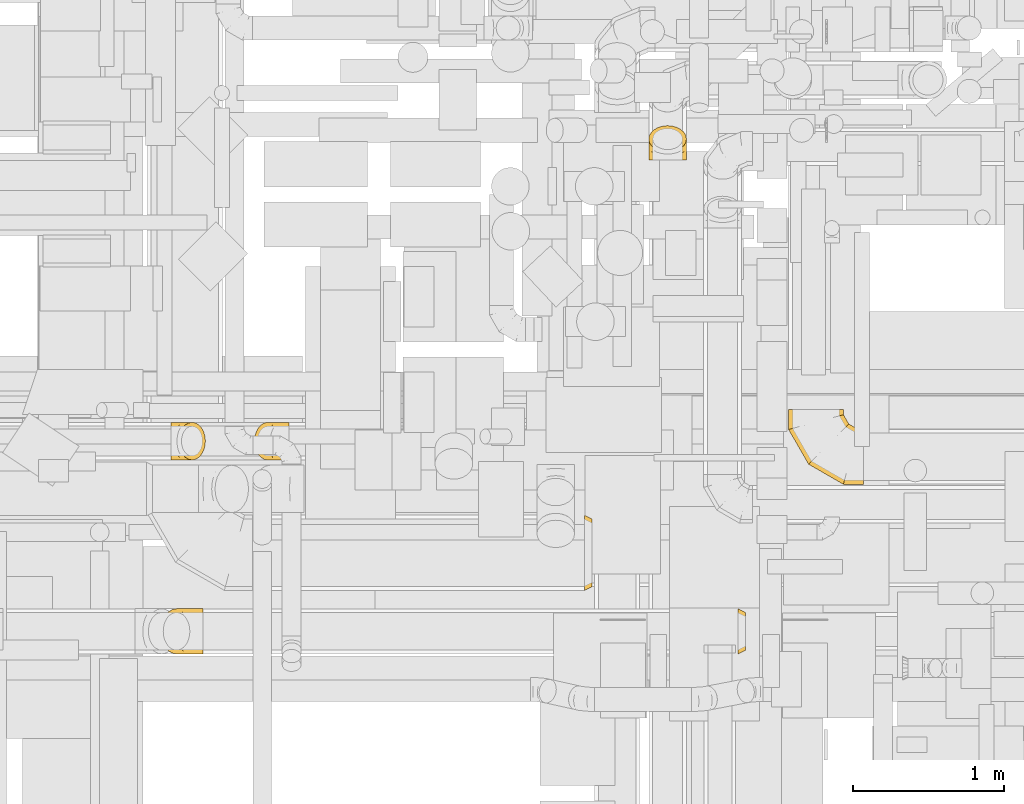
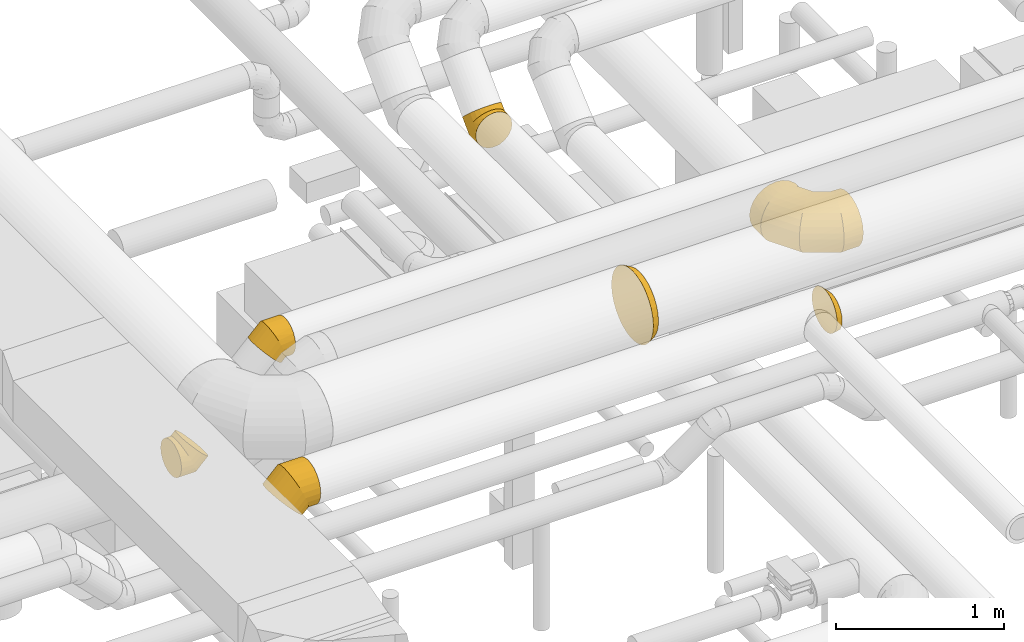
# One storey, part 8 of 337: 7 coverings.
"""IFC2X3 building model written with IfcOpenShell, lengths in millimetres."""

import ifcopenshell
import ifcopenshell.guid

model = None  # the IFC model being written
_history = None  # IfcOwnerHistory: only IFC2X3 demands one
_inside = {}  # id of a spatial element -> (the spatial element, [elements in it])
_under = {}  # id of a project, library or spatial element -> (it, [spatial elements below it])
_declared = {}  # id of a project -> (the project, [libraries it declares])
_typed = {}  # id of a type object -> (the type object, [elements of that type])
_made_of = {}  # id of a material, layer set ... -> (it, [elements and type objects made of it])


def new_model(schema):
    """Start an empty IFC model of exactly this schema.

    Asked for "IFC4X3", IfcOpenShell would pick the latest addendum, in which some entities
    have other attributes; the version numbers below select the first issue.
    IFC2X3 requires an IfcOwnerHistory on every rooted entity: one is made here for all.
    """
    global model, _history
    if schema == "IFC4X3":
        model = ifcopenshell.file(schema_version=(4, 3, 0, 0))
    else:
        model = ifcopenshell.file(schema=schema)
    _inside.clear()
    _under.clear()
    _declared.clear()
    _typed.clear()
    _made_of.clear()
    _history = None
    if model.schema == "IFC2X3":
        org = make("IfcOrganization", Name="unknown")
        user = make(
            "IfcPersonAndOrganization",
            ThePerson=make("IfcPerson", FamilyName="unknown"),
            TheOrganization=org,
        )
        app = make(
            "IfcApplication",
            ApplicationDeveloper=org,
            Version="unknown",
            ApplicationFullName="unknown",
            ApplicationIdentifier="unknown",
        )
        _history = make(
            "IfcOwnerHistory",
            OwningUser=user,
            OwningApplication=app,
            ChangeAction="ADDED",
            CreationDate=0,
        )
    return model


def make(cls, **values):
    """One entity of the class cls with the attributes given. An attribute that is None is left unset."""
    return model.create_entity(
        cls, **{name: value for name, value in values.items() if value is not None}
    )


def entity(cls, *values):
    """Any entity or typed value of the class cls, its attributes in the order of the schema. None: left unset."""
    e = model.create_entity(cls)
    for i, value in enumerate(values):
        if value is not None:
            e[i] = value
    return e


def rooted(cls, **values):
    """An entity with a GlobalId (a new one), such as an element, a storey or a relation."""
    return make(cls, GlobalId=ifcopenshell.guid.new(), OwnerHistory=_history, **values)


def si_unit(unit_type, name, prefix=None):
    """IfcSIUnit, for example si_unit("LENGTHUNIT", "METRE", prefix="MILLI")."""
    return make("IfcSIUnit", UnitType=unit_type, Prefix=prefix, Name=name)


def converted_unit(unit_type, name, factor, base, dimensions=None, offset=None):
    """IfcConversionBasedUnit, such as the inch: factor (a typed value) times the base unit."""
    return make(
        "IfcConversionBasedUnit"
        if offset is None
        else "IfcConversionBasedUnitWithOffset",
        ConversionOffset=offset,
        Dimensions=None
        if dimensions is None
        else entity("IfcDimensionalExponents", *dimensions),
        UnitType=unit_type,
        Name=name,
        ConversionFactor=make(
            "IfcMeasureWithUnit", ValueComponent=factor, UnitComponent=base
        ),
    )


def derived_unit(unit_type, elements):
    """IfcDerivedUnit: a product of units, each with its exponent."""
    return make(
        "IfcDerivedUnit",
        Elements=[
            make("IfcDerivedUnitElement", Unit=unit, Exponent=power)
            for unit, power in elements
        ],
        UnitType=unit_type,
    )


def assignment(units):
    """IfcUnitAssignment: the units of a project."""
    return None if units is None else make("IfcUnitAssignment", Units=units)


def point(xyz):
    """IfcCartesianPoint."""
    return None if xyz is None else make("IfcCartesianPoint", Coordinates=xyz)


def direction(xyz):
    """IfcDirection."""
    return None if xyz is None else make("IfcDirection", DirectionRatios=xyz)


def frame(location, z_axis=None, x_axis=None):
    """IfcAxis2Placement3D, a coordinate frame: its origin and axes. An axis left out is left unset."""
    return make(
        "IfcAxis2Placement3D",
        Location=point(location),
        Axis=direction(z_axis),
        RefDirection=direction(x_axis),
    )


def origin():
    """The frame at (0, 0, 0) with its axes left unset."""
    return frame((0.0, 0.0, 0.0))


def place(relative_to, where):
    """IfcLocalPlacement: puts the frame where relative to a parent placement (None: the world)."""
    return make(
        "IfcLocalPlacement", PlacementRelTo=relative_to, RelativePlacement=where
    )


def context(
    kind, dimensions, precision=None, world=None, true_north=None, identifier=None
):
    """IfcGeometricRepresentationContext, for example the 3D "Model" context."""
    return make(
        "IfcGeometricRepresentationContext",
        ContextIdentifier=identifier,
        ContextType=kind,
        CoordinateSpaceDimension=dimensions,
        Precision=precision,
        WorldCoordinateSystem=world,
        TrueNorth=true_north,
    )


def subcontext(parent, identifier, kind, view, scale=None):
    """IfcGeometricRepresentationSubContext, for example "Body" below "Model"."""
    return make(
        "IfcGeometricRepresentationSubContext",
        ContextIdentifier=identifier,
        ContextType=kind,
        ParentContext=parent,
        TargetScale=scale,
        TargetView=view,
    )


def project(units=None, contexts=None):
    """IfcProject with its units and contexts."""
    return rooted(
        "IfcProject",
        Name="project",
        RepresentationContexts=contexts,
        UnitsInContext=assignment(units),
    )


def spatial(cls, under=None, at=None, **own):
    """A site, building, storey or space (cls), placed at a placement, below another one or the project."""
    s = rooted(cls, ObjectPlacement=at, **own)
    if under is not None:
        _under.setdefault(under.id(), (under, []))[1].append(s)
    return s


def faces_of(points, faces, orient=None, outer=None):
    """IfcFace entities. A face is a list of loops; a loop is a list of indices into points, from 0.

    orient and outer hold one flag for each loop. By default every Orientation is true, the
    first loop of a face is its IfcFaceOuterBound and the others are IfcFaceBound.
    """
    made = []
    for i, loops in enumerate(faces):
        bounds = []
        for j, loop in enumerate(loops):
            is_outer = j == 0 if outer is None else outer[i][j]
            bounds.append(
                make(
                    "IfcFaceOuterBound" if is_outer else "IfcFaceBound",
                    Bound=make("IfcPolyLoop", Polygon=[points[k] for k in loop]),
                    Orientation=True if orient is None else orient[i][j],
                )
            )
        made.append(make("IfcFace", Bounds=bounds))
    return made


def faceted_brep(points, faces, orient=None, outer=None, voids=None):
    """IfcFacetedBrep: a solid bounded by flat faces; with voids (closed shells), ...WithVoids."""
    shared = [point(p) for p in points]
    hull = make("IfcClosedShell", CfsFaces=faces_of(shared, faces, orient, outer))
    if voids is None:
        return make("IfcFacetedBrep", Outer=hull)
    return make(
        "IfcFacetedBrepWithVoids",
        Outer=hull,
        Voids=[
            make(cls, CfsFaces=faces_of(shared, fs, o, b)) for cls, fs, o, b in voids
        ],
    )


def shape(context_of_items, identifier, shape_type, items):
    """IfcShapeRepresentation: the items that make up one representation, for example the "Body"."""
    return make(
        "IfcShapeRepresentation",
        ContextOfItems=context_of_items,
        RepresentationIdentifier=identifier,
        RepresentationType=shape_type,
        Items=items,
    )


def made_of(thing, what):
    """Note that an element or type object is made of a material, layer set ...; save() writes the relation."""
    if what is not None:
        _made_of.setdefault(what.id(), (what, []))[1].append(thing)
    return thing


def element(
    cls,
    number,
    at=None,
    inside=None,
    cuts=None,
    type_object=None,
    material=None,
    context=None,
    identifier="Body",
    shape_type=None,
    held_by="IfcProductDefinitionShape",
    body=None,
    shapes=None,
    **own,
):
    """One element of the class cls, such as IfcWall. Its Tag is "e" and its number.

    at: its placement. inside: the storey or other place that contains it. cuts: it is an
    opening in that element (IfcRelVoidsElement). A single representation is given by context,
    identifier, shape_type and body (its items); several are given by shapes. held_by: the class
    of the entity that holds the representations. save() writes the other relations.
    """
    e = rooted(cls, Tag="e%d" % number, ObjectPlacement=at, **own)
    if body is not None:
        shapes = [shape(context, identifier, shape_type, body)]
    if shapes is not None:
        e.Representation = make(held_by, Representations=shapes)
    if inside is not None:
        _inside.setdefault(inside.id(), (inside, []))[1].append(e)
    if cuts is not None:
        rooted(
            "IfcRelVoidsElement", RelatingBuildingElement=cuts, RelatedOpeningElement=e
        )
    if type_object is not None:
        _typed.setdefault(type_object.id(), (type_object, []))[1].append(e)
    return made_of(e, material)


def aggregate(whole, parts):
    """IfcRelAggregates: a whole, such as a stair, and the parts it consists of."""
    return rooted("IfcRelAggregates", RelatingObject=whole, RelatedObjects=parts)


def save(model, path):
    """Write the relations noted so far, then the file.

    IfcRelAggregates (storeys below a building ...), IfcRelContainedInSpatialStructure (elements
    in a storey), IfcRelDefinesByType, IfcRelAssociatesMaterial and IfcRelDeclares: one each for
    every whole, place, type object, material and project.
    """
    for whole, parts in _under.values():
        aggregate(whole, parts)
    for where, things in _inside.values():
        rooted(
            "IfcRelContainedInSpatialStructure",
            RelatedElements=things,
            RelatingStructure=where,
        )
    for kind, things in _typed.values():
        rooted("IfcRelDefinesByType", RelatedObjects=things, RelatingType=kind)
    for what, things in _made_of.values():
        rooted("IfcRelAssociatesMaterial", RelatedObjects=things, RelatingMaterial=what)
    for by, libraries in _declared.values():
        rooted("IfcRelDeclares", RelatingContext=by, RelatedDefinitions=libraries)
    model.write(path)


model = new_model("IFC2X3")

# Units and contexts
model_context = context("Model", 3, precision=0.01, world=origin(), true_north=direction((6.12303176911189e-17, 1.0)))
body_context = subcontext(model_context, "Body", "Model", "MODEL_VIEW")
ifc_project = project(units=[si_unit("LENGTHUNIT", "METRE", prefix="MILLI"), si_unit("AREAUNIT", "SQUARE_METRE"), si_unit("VOLUMEUNIT", "CUBIC_METRE"), converted_unit("PLANEANGLEUNIT", "DEGREE", entity("IfcRatioMeasure", 0.0174532925199433), si_unit("PLANEANGLEUNIT", "RADIAN"), dimensions=[0, 0, 0, 0, 0, 0, 0]), si_unit("MASSUNIT", "GRAM", prefix="KILO"), derived_unit("MASSDENSITYUNIT", [(si_unit("MASSUNIT", "GRAM", prefix="KILO"), 1), (si_unit("LENGTHUNIT", "METRE"), -3)]), derived_unit("MOMENTOFINERTIAUNIT", [(si_unit("LENGTHUNIT", "METRE"), 4)]), si_unit("TIMEUNIT", "SECOND"), si_unit("FREQUENCYUNIT", "HERTZ"), si_unit("THERMODYNAMICTEMPERATUREUNIT", "DEGREE_CELSIUS"), derived_unit("THERMALTRANSMITTANCEUNIT", [(si_unit("MASSUNIT", "GRAM", prefix="KILO"), 1), (si_unit("THERMODYNAMICTEMPERATUREUNIT", "KELVIN"), -1), (si_unit("TIMEUNIT", "SECOND"), -3)]), derived_unit("VOLUMETRICFLOWRATEUNIT", [(si_unit("LENGTHUNIT", "METRE"), 3), (si_unit("TIMEUNIT", "SECOND"), -1)]), derived_unit("MASSFLOWRATEUNIT", [(si_unit("MASSUNIT", "GRAM", prefix="KILO"), 1), (si_unit("TIMEUNIT", "SECOND"), -1)]), derived_unit("ROTATIONALFREQUENCYUNIT", [(si_unit("TIMEUNIT", "SECOND"), -1)]), si_unit("ELECTRICCURRENTUNIT", "AMPERE"), si_unit("ELECTRICVOLTAGEUNIT", "VOLT"), si_unit("POWERUNIT", "WATT"), si_unit("FORCEUNIT", "NEWTON", prefix="KILO"), si_unit("ILLUMINANCEUNIT", "LUX"), si_unit("LUMINOUSFLUXUNIT", "LUMEN"), si_unit("LUMINOUSINTENSITYUNIT", "CANDELA"), derived_unit("USERDEFINED", [(si_unit("MASSUNIT", "GRAM", prefix="KILO"), -1), (si_unit("LENGTHUNIT", "METRE"), -2), (si_unit("TIMEUNIT", "SECOND"), 3), (si_unit("LUMINOUSFLUXUNIT", "LUMEN"), 1)]), derived_unit("LINEARVELOCITYUNIT", [(si_unit("LENGTHUNIT", "METRE"), 1), (si_unit("TIMEUNIT", "SECOND"), -1)]), si_unit("PRESSUREUNIT", "PASCAL"), derived_unit("USERDEFINED", [(si_unit("LENGTHUNIT", "METRE"), -2), (si_unit("MASSUNIT", "GRAM", prefix="KILO"), 1), (si_unit("TIMEUNIT", "SECOND"), -2)]), derived_unit("LINEARFORCEUNIT", [(si_unit("MASSUNIT", "GRAM", prefix="KILO"), 1), (si_unit("LENGTHUNIT", "METRE"), 1), (si_unit("TIMEUNIT", "SECOND"), -2), (si_unit("LENGTHUNIT", "METRE"), -1)]), derived_unit("PLANARFORCEUNIT", [(si_unit("MASSUNIT", "GRAM", prefix="KILO"), 1), (si_unit("LENGTHUNIT", "METRE"), 1), (si_unit("TIMEUNIT", "SECOND"), -2), (si_unit("LENGTHUNIT", "METRE"), -2)])], contexts=[model_context])

# Site, building, storey
site_placement = place(None, origin())
site = spatial("IfcSite", under=ifc_project, at=site_placement, CompositionType="ELEMENT")
building_placement = place(site_placement, origin())
building = spatial("IfcBuilding", under=site, at=building_placement, CompositionType="ELEMENT")
storey_placement = place(building_placement, origin())
storey = spatial("IfcBuildingStorey", under=building, at=storey_placement, CompositionType="ELEMENT", Elevation=0.0)

# Coverings
covering_1_placement = place(storey_placement, frame((46761.95, 9723.4, 2773.4)))
element("IfcCovering", 1, at=covering_1_placement, inside=storey, PredefinedType="INSULATION", context=body_context, shape_type="Brep", body=[
    faceted_brep([(0.0, 87.97, 245.48), (0.0, 126.6, 251.6), (0.0, 165.22, 245.48), (0.0, 200.07, 227.72), (0.0, 227.72, 200.07), (0.0, 245.48, 165.22), (0.0, 251.6, 126.6), (0.0, 245.48, 87.97), (0.0, 227.72, 53.12), (0.0, 200.07, 25.47), (0.0, 165.22, 7.71), (0.0, 126.6, 1.6), (0.0, 87.97, 7.71), (0.0, 53.12, 25.47), (0.0, 25.47, 53.12), (0.0, 7.71, 87.97), (0.0, 1.6, 126.6), (0.0, 7.71, 165.22), (0.0, 25.47, 200.07), (0.0, 53.12, 227.72), (226.8, 94.24, 99.8), (229.81, 126.6, 96.79), (226.8, 158.95, 99.8), (217.97, 189.1, 108.63), (203.92, 214.98, 122.67), (185.62, 234.85, 140.98), (164.3, 247.34, 162.3), (141.42, 251.6, 185.17), (118.54, 247.34, 208.05), (97.23, 234.85, 229.37), (78.92, 214.98, 247.67), (64.87, 189.1, 261.72), (56.04, 158.95, 270.55), (53.03, 126.6, 273.56), (56.04, 94.24, 270.55), (64.87, 64.1, 261.72), (78.92, 38.21, 247.67), (97.23, 18.34, 229.37), (118.54, 5.85, 208.05), (141.42, 1.6, 185.17), (164.3, 5.85, 162.3), (185.62, 18.34, 140.98), (203.92, 38.21, 122.67), (217.97, 64.1, 108.63), (134.62, 126.6, 1.6), (132.86, 158.95, 5.85), (127.68, 189.1, 18.34), (119.45, 214.98, 38.21), (108.73, 234.85, 64.1), (96.24, 247.34, 94.24), (82.84, 251.6, 126.6), (69.44, 247.34, 158.95), (56.95, 234.85, 189.1), (46.23, 214.98, 214.98), (32.83, 158.95, 247.34), (31.07, 126.6, 251.6), (38.0, 189.1, 234.85), (38.0, 64.1, 234.85), (46.23, 38.21, 214.98), (32.83, 94.24, 247.34), (69.44, 5.85, 158.95), (82.84, 1.6, 126.6), (56.95, 18.34, 189.1), (96.24, 5.85, 94.24), (108.73, 18.34, 64.1), (119.45, 38.21, 38.21), (127.68, 64.1, 18.34), (132.86, 94.24, 5.85)], [[[0, 1, 2, 3, 4, 5, 6, 7, 8, 9, 10, 11, 12, 13, 14, 15, 16, 17, 18, 19]], [[20, 21, 22, 23, 24, 25, 26, 27, 28, 29, 30, 31, 32, 33, 34, 35, 36, 37, 38, 39, 40, 41, 42, 43]], [[21, 44, 45, 22]], [[22, 45, 46, 23]], [[47, 24, 23, 46]], [[24, 47, 48, 25]], [[25, 48, 49, 26]], [[50, 27, 26, 49]], [[51, 52, 29, 28]], [[50, 51, 28, 27]], [[29, 52, 53, 30]], [[54, 55, 33, 32]], [[56, 54, 32, 31]], [[30, 53, 56, 31]], [[35, 57, 58, 36]], [[59, 57, 35, 34]], [[33, 55, 59, 34]], [[60, 61, 39, 38]], [[62, 60, 38, 37]], [[58, 62, 37, 36]], [[40, 39, 61, 63]], [[41, 40, 63, 64]], [[64, 65, 42, 41]], [[20, 43, 66, 67]], [[21, 20, 67, 44]], [[65, 66, 43, 42]], [[10, 9, 46]], [[11, 10, 45]], [[11, 45, 44]], [[45, 10, 46]], [[9, 47, 46]], [[48, 8, 7]], [[49, 7, 6]], [[47, 8, 48]], [[48, 7, 49]], [[6, 50, 49]], [[8, 47, 9]], [[5, 4, 52]], [[6, 5, 51]], [[51, 50, 6]], [[52, 51, 5]], [[4, 53, 52]], [[56, 3, 2]], [[54, 2, 1]], [[56, 53, 3]], [[55, 54, 1]], [[56, 2, 54]], [[3, 53, 4]], [[0, 19, 57]], [[1, 0, 59]], [[59, 55, 1]], [[57, 59, 0]], [[19, 58, 57]], [[62, 18, 17]], [[60, 17, 16]], [[62, 58, 18]], [[61, 60, 16]], [[62, 17, 60]], [[18, 58, 19]], [[63, 16, 15]], [[64, 15, 14]], [[16, 63, 61]], [[63, 15, 64]], [[14, 65, 64]], [[66, 13, 12]], [[67, 12, 11]], [[65, 13, 66]], [[67, 66, 12]], [[44, 67, 11]], [[13, 65, 14]]]),
])
covering_2_placement = place(storey_placement, frame((46692.39, 8435.07, 3244.12)))
element("IfcCovering", 2, at=covering_2_placement, inside=storey, PredefinedType="INSULATION", context=body_context, shape_type="Brep", body=[
    faceted_brep([(284.44, 151.6, 30.88), (284.44, 190.42, 36.0), (284.44, 226.6, 50.98), (284.44, 257.66, 74.82), (284.44, 281.5, 105.88), (284.44, 296.48, 142.06), (284.44, 301.6, 180.88), (284.44, 296.48, 219.71), (284.44, 281.5, 255.88), (284.44, 257.66, 286.95), (284.44, 226.6, 310.79), (284.44, 190.42, 325.77), (284.44, 151.6, 330.88), (284.44, 112.77, 325.77), (284.44, 76.6, 310.79), (284.44, 45.53, 286.95), (284.44, 21.69, 255.88), (284.44, 6.71, 219.71), (284.44, 1.6, 180.88), (284.44, 6.71, 142.06), (284.44, 21.69, 105.88), (284.44, 45.53, 74.82), (284.44, 76.6, 50.98), (284.44, 112.77, 36.0), (15.81, 76.6, 199.52), (5.21, 112.77, 210.11), (1.6, 151.6, 213.73), (5.21, 190.42, 210.11), (15.81, 226.6, 199.52), (32.66, 257.66, 182.66), (54.63, 281.5, 160.69), (80.21, 296.48, 135.11), (107.66, 301.6, 107.66), (135.11, 296.48, 80.21), (160.69, 281.5, 54.63), (182.66, 257.66, 32.66), (199.52, 226.6, 15.81), (210.11, 190.42, 5.21), (213.73, 151.6, 1.6), (210.11, 112.77, 5.21), (199.52, 76.6, 15.81), (182.66, 45.53, 32.66), (160.69, 21.69, 54.63), (135.11, 6.71, 80.21), (107.66, 1.6, 107.66), (80.21, 6.71, 135.11), (54.63, 21.69, 160.69), (32.66, 45.53, 182.66), (118.75, 151.6, 330.88), (120.87, 190.42, 325.77), (127.08, 226.6, 310.79), (136.95, 257.66, 286.95), (149.82, 281.5, 255.88), (164.8, 296.48, 219.71), (180.88, 301.6, 180.88), (196.97, 296.48, 142.06), (211.95, 281.5, 105.88), (224.82, 257.66, 74.82), (240.9, 190.42, 36.0), (243.02, 151.6, 30.88), (234.69, 226.6, 50.98), (234.69, 76.6, 50.98), (224.82, 45.53, 74.82), (240.9, 112.77, 36.0), (196.97, 6.71, 142.06), (180.88, 1.6, 180.88), (211.95, 21.69, 105.88), (164.8, 6.71, 219.71), (149.82, 21.69, 255.88), (136.95, 45.53, 286.95), (127.08, 76.6, 310.79), (120.87, 112.77, 325.77)], [[[0, 1, 2, 3, 4, 5, 6, 7, 8, 9, 10, 11, 12, 13, 14, 15, 16, 17, 18, 19, 20, 21, 22, 23]], [[24, 25, 26, 27, 28, 29, 30, 31, 32, 33, 34, 35, 36, 37, 38, 39, 40, 41, 42, 43, 44, 45, 46, 47]], [[26, 48, 49, 27]], [[27, 49, 50, 28]], [[51, 29, 28, 50]], [[29, 51, 52, 30]], [[30, 52, 53, 31]], [[54, 32, 31, 53]], [[55, 56, 34, 33]], [[54, 55, 33, 32]], [[34, 56, 57, 35]], [[58, 59, 38, 37]], [[60, 58, 37, 36]], [[35, 57, 60, 36]], [[40, 61, 62, 41]], [[63, 61, 40, 39]], [[38, 59, 63, 39]], [[64, 65, 44, 43]], [[66, 64, 43, 42]], [[62, 66, 42, 41]], [[45, 44, 65, 67]], [[46, 45, 67, 68]], [[68, 69, 47, 46]], [[25, 24, 70, 71]], [[26, 25, 71, 48]], [[69, 70, 24, 47]], [[11, 10, 50, 49]], [[12, 11, 49, 48]], [[10, 9, 51, 50]], [[53, 52, 8, 7]], [[54, 53, 7, 6]], [[9, 8, 52, 51]], [[5, 4, 56, 55]], [[6, 5, 55, 54]], [[57, 56, 4, 3]], [[58, 60, 2, 1]], [[59, 58, 1, 0]], [[3, 2, 60, 57]], [[59, 0, 23, 63]], [[63, 23, 22, 61]], [[21, 62, 61, 22]], [[66, 20, 19, 64]], [[64, 19, 18, 65]], [[20, 66, 62, 21]], [[65, 18, 17, 67]], [[67, 17, 16, 68]], [[15, 69, 68, 16]], [[70, 14, 13, 71]], [[71, 13, 12, 48]], [[14, 70, 69, 15]]]),
])
covering_3_placement = place(storey_placement, frame((50864.17, 9561.79, 2915.88)))
element("IfcCovering", 3, at=covering_3_placement, inside=storey, PredefinedType="INSULATION", context=body_context, shape_type="Brep", body=[
    faceted_brep([(499.09, 184.1, 366.6), (499.09, 136.86, 360.38), (499.09, 92.85, 342.15), (499.09, 55.05, 313.14), (499.09, 26.05, 275.35), (499.09, 7.81, 231.33), (499.1, 1.6, 184.1), (499.1, 7.81, 136.86), (499.1, 26.05, 92.85), (499.1, 55.05, 55.05), (499.1, 92.85, 26.05), (499.1, 136.86, 7.82), (499.1, 184.1, 1.6), (499.1, 231.33, 7.82), (499.1, 275.35, 26.05), (499.1, 313.14, 55.05), (499.1, 342.15, 92.85), (499.1, 360.38, 136.86), (499.1, 366.6, 184.1), (499.09, 360.38, 231.33), (499.09, 342.14, 275.35), (499.09, 313.14, 313.14), (499.09, 275.35, 342.15), (499.09, 231.33, 360.38), (7.81, 499.1, 136.86), (1.6, 499.1, 184.09), (7.81, 499.1, 231.33), (26.04, 499.1, 275.34), (55.05, 499.1, 313.14), (92.84, 499.1, 342.14), (136.86, 499.1, 360.38), (184.09, 499.1, 366.6), (231.33, 499.1, 360.38), (275.34, 499.1, 342.15), (313.14, 499.1, 313.14), (342.14, 499.1, 275.35), (360.38, 499.1, 231.33), (366.6, 499.1, 184.1), (360.38, 499.1, 136.86), (342.15, 499.1, 92.85), (313.14, 499.1, 55.05), (275.35, 499.1, 26.05), (231.33, 499.1, 7.81), (184.1, 499.1, 1.6), (136.86, 499.1, 7.81), (92.85, 499.1, 26.04), (55.05, 499.1, 55.05), (26.05, 499.1, 92.84), (1.6, 365.79, 184.09), (6.17, 367.02, 224.7), (19.67, 370.63, 263.28), (41.41, 376.46, 297.88), (70.31, 384.2, 326.78), (104.91, 393.47, 348.52), (143.48, 403.81, 362.02), (184.09, 414.69, 366.6), (224.7, 425.57, 362.02), (263.28, 435.91, 348.52), (297.88, 445.18, 326.78), (326.78, 452.92, 297.88), (348.52, 458.75, 263.28), (362.02, 462.37, 224.71), (366.6, 463.59, 184.1), (348.52, 458.75, 104.91), (326.78, 452.92, 70.31), (362.02, 462.37, 143.49), (297.88, 445.18, 41.41), (263.28, 435.91, 19.67), (224.71, 425.57, 6.17), (184.1, 414.69, 1.6), (143.49, 403.81, 6.17), (104.91, 393.47, 19.67), (70.31, 384.2, 41.41), (41.41, 376.46, 70.31), (19.67, 370.63, 104.91), (6.17, 367.02, 143.48), (134.9, 134.9, 184.09), (138.25, 138.25, 224.7), (148.13, 148.13, 263.28), (164.05, 164.05, 297.88), (185.2, 185.2, 326.78), (210.53, 210.53, 348.52), (238.77, 238.77, 362.02), (268.5, 268.5, 366.6), (298.23, 298.23, 362.02), (326.46, 326.47, 348.52), (351.8, 351.8, 326.78), (372.95, 372.95, 297.88), (388.87, 388.87, 263.28), (398.75, 398.75, 224.71), (402.1, 402.1, 184.1), (398.75, 398.75, 143.49), (388.87, 388.87, 104.91), (372.95, 372.95, 70.31), (351.8, 351.8, 41.41), (326.47, 326.47, 19.67), (298.23, 298.23, 6.17), (268.5, 268.5, 1.6), (238.77, 238.77, 6.17), (210.53, 210.53, 19.67), (185.2, 185.2, 41.41), (164.05, 164.05, 70.31), (148.13, 148.13, 104.91), (138.25, 138.25, 143.48), (365.79, 1.6, 184.1), (367.02, 6.17, 224.71), (370.63, 19.67, 263.28), (376.46, 41.41, 297.88), (384.2, 70.31, 326.78), (393.47, 104.91, 348.52), (403.81, 143.49, 362.02), (414.69, 184.1, 366.6), (425.57, 224.71, 362.02), (435.91, 263.28, 348.52), (445.18, 297.88, 326.78), (452.92, 326.78, 297.88), (458.75, 348.52, 263.28), (462.37, 362.02, 224.71), (463.59, 366.6, 184.1), (462.37, 362.02, 143.49), (458.75, 348.52, 104.91), (452.92, 326.78, 70.31), (445.18, 297.88, 41.41), (435.91, 263.28, 19.67), (425.57, 224.71, 6.17), (414.69, 184.1, 1.6), (403.81, 143.49, 6.17), (393.48, 104.91, 19.67), (384.2, 70.31, 41.41), (376.46, 41.41, 70.31), (370.63, 19.67, 104.91), (367.02, 6.17, 143.49)], [[[0, 1, 2, 3, 4, 5, 6, 7, 8, 9, 10, 11, 12, 13, 14, 15, 16, 17, 18, 19, 20, 21, 22, 23]], [[24, 25, 26, 27, 28, 29, 30, 31, 32, 33, 34, 35, 36, 37, 38, 39, 40, 41, 42, 43, 44, 45, 46, 47]], [[25, 48, 49]], [[26, 49, 50]], [[25, 49, 26]], [[27, 51, 28]], [[27, 26, 50]], [[51, 27, 50]], [[29, 52, 53]], [[30, 53, 54]], [[31, 54, 55]], [[28, 52, 29]], [[29, 53, 30]], [[54, 31, 30]], [[52, 28, 51]], [[56, 57, 32]], [[55, 56, 31]], [[31, 56, 32]], [[33, 58, 34]], [[33, 32, 57]], [[58, 33, 57]], [[59, 60, 35]], [[61, 62, 37]], [[60, 61, 36]], [[34, 59, 35]], [[35, 60, 36]], [[61, 37, 36]], [[59, 34, 58]], [[63, 64, 39]], [[65, 63, 38]], [[62, 65, 37]], [[37, 65, 38]], [[63, 39, 38]], [[64, 40, 39]], [[66, 67, 41]], [[68, 69, 43]], [[67, 68, 42]], [[40, 66, 41]], [[41, 67, 42]], [[68, 43, 42]], [[66, 40, 64]], [[44, 70, 71]], [[45, 71, 72]], [[69, 70, 43]], [[43, 70, 44]], [[71, 45, 44]], [[72, 46, 45]], [[47, 73, 74]], [[74, 75, 24]], [[48, 25, 75]], [[46, 73, 47]], [[47, 74, 24]], [[75, 25, 24]], [[73, 46, 72]], [[49, 48, 76, 77]], [[50, 49, 77, 78]], [[51, 50, 78, 79]], [[79, 80, 52, 51]], [[53, 52, 80, 81]], [[54, 53, 81, 82]], [[55, 54, 82, 83]], [[83, 84, 56, 55]], [[85, 86, 58, 57]], [[84, 85, 57, 56]], [[86, 87, 59, 58]], [[87, 88, 60, 59]], [[89, 90, 62, 61]], [[88, 89, 61, 60]], [[90, 91, 65, 62]], [[92, 93, 64, 63]], [[91, 92, 63, 65]], [[93, 94, 66, 64]], [[94, 95, 67, 66]], [[96, 97, 69, 68]], [[95, 96, 68, 67]], [[70, 69, 97, 98]], [[98, 99, 71, 70]], [[100, 72, 71, 99]], [[100, 101, 73, 72]], [[74, 73, 101, 102]], [[102, 103, 75, 74]], [[76, 48, 75, 103]], [[77, 76, 104, 105]], [[78, 77, 105, 106]], [[79, 78, 106, 107]], [[107, 108, 80, 79]], [[81, 80, 108, 109]], [[82, 81, 109, 110]], [[83, 82, 110, 111]], [[111, 112, 84, 83]], [[113, 114, 86, 85]], [[112, 113, 85, 84]], [[114, 115, 87, 86]], [[115, 116, 88, 87]], [[117, 118, 90, 89]], [[116, 117, 89, 88]], [[118, 119, 91, 90]], [[120, 121, 93, 92]], [[119, 120, 92, 91]], [[121, 122, 94, 93]], [[122, 123, 95, 94]], [[124, 125, 97, 96]], [[123, 124, 96, 95]], [[98, 97, 125, 126]], [[126, 127, 99, 98]], [[128, 100, 99, 127]], [[128, 129, 101, 100]], [[102, 101, 129, 130]], [[130, 131, 103, 102]], [[104, 76, 103, 131]], [[105, 6, 5]], [[106, 5, 4]], [[104, 6, 105]], [[105, 5, 106]], [[4, 107, 106]], [[4, 3, 107]], [[108, 3, 2]], [[109, 2, 1]], [[110, 1, 0]], [[108, 2, 109]], [[109, 1, 110]], [[0, 111, 110]], [[3, 108, 107]], [[112, 0, 23]], [[113, 23, 22]], [[112, 111, 0]], [[114, 113, 22]], [[112, 23, 113]], [[22, 21, 114]], [[115, 21, 20]], [[116, 20, 19]], [[117, 19, 18]], [[116, 115, 20]], [[118, 117, 18]], [[116, 19, 117]], [[21, 115, 114]], [[119, 18, 17]], [[120, 17, 16]], [[119, 118, 18]], [[121, 120, 16]], [[119, 17, 120]], [[16, 15, 121]], [[122, 15, 14]], [[123, 14, 13]], [[124, 13, 12]], [[123, 122, 14]], [[125, 124, 12]], [[123, 13, 124]], [[15, 122, 121]], [[126, 12, 11]], [[127, 11, 10]], [[125, 12, 126]], [[127, 126, 11]], [[128, 127, 10]], [[10, 9, 128]], [[129, 9, 8]], [[130, 8, 7]], [[131, 7, 6]], [[129, 8, 130]], [[131, 130, 7]], [[104, 131, 6]], [[9, 129, 128]]]),
])
covering_4_placement = place(storey_placement, frame((50531.4, 8435.07, 3273.4)))
element("IfcCovering", 4, at=covering_4_placement, inside=storey, PredefinedType="INSULATION", context=body_context, shape_type="Brep", body=[
    faceted_brep([(50.0, 151.6, 251.6), (50.0, 112.97, 245.48), (50.0, 78.12, 227.72), (50.0, 64.3, 213.9), (50.0, 50.47, 200.07), (50.0, 32.71, 165.22), (50.0, 26.6, 126.6), (50.0, 32.71, 87.97), (50.0, 50.47, 53.12), (50.0, 64.3, 39.3), (50.0, 78.12, 25.47), (50.0, 112.97, 7.71), (50.0, 151.6, 1.6), (50.0, 190.22, 7.71), (50.0, 225.07, 25.47), (50.0, 238.9, 39.3), (50.0, 252.72, 53.12), (50.0, 270.48, 87.97), (50.0, 276.6, 126.6), (50.0, 270.48, 165.22), (50.0, 252.72, 200.07), (50.0, 238.9, 213.9), (50.0, 225.07, 227.72), (50.0, 190.22, 245.48), (0.0, 151.6, 301.6), (0.0, 190.42, 296.48), (0.0, 226.6, 281.5), (0.0, 257.66, 257.66), (0.0, 281.5, 226.6), (0.0, 296.48, 190.42), (0.0, 301.6, 151.6), (0.0, 296.48, 112.77), (0.0, 281.5, 76.6), (0.0, 257.66, 45.53), (0.0, 226.6, 21.69), (0.0, 190.42, 6.71), (0.0, 151.6, 1.6), (0.0, 112.77, 6.71), (0.0, 76.6, 21.69), (0.0, 45.53, 45.53), (0.0, 21.69, 76.6), (0.0, 6.71, 112.77), (0.0, 1.6, 151.6), (0.0, 6.71, 190.42), (0.0, 21.69, 226.6), (0.0, 45.53, 257.66), (0.0, 76.6, 281.5), (0.0, 112.77, 296.48), (29.01, 18.74, 110.46), (25.11, 14.15, 139.04), (22.27, 12.73, 140.46), (23.18, 23.72, 87.04), (25.11, 151.6, 1.6), (29.01, 124.97, 4.24), (24.36, 37.4, 62.25), (23.18, 98.63, 12.13), (24.36, 74.43, 25.22), (24.64, 54.24, 41.92), (29.01, 178.22, 4.24), (23.18, 204.56, 12.13), (29.01, 284.45, 110.46), (22.27, 290.46, 140.46), (25.11, 289.04, 139.04), (24.36, 228.76, 25.22), (23.18, 279.47, 87.04), (24.36, 265.79, 62.25), (24.64, 248.95, 41.92), (28.9, 284.56, 163.47), (23.18, 279.47, 192.97), (24.36, 265.79, 216.58), (22.27, 151.6, 279.33), (28.9, 177.92, 270.11), (23.18, 204.56, 267.88), (24.64, 248.95, 236.63), (24.36, 228.76, 253.61), (28.9, 125.27, 270.11), (23.18, 98.63, 267.88), (24.36, 74.43, 253.61), (28.9, 18.63, 163.47), (23.18, 23.72, 192.97), (24.64, 54.24, 236.63), (24.36, 37.4, 216.58)], [[[0, 1, 2, 3, 4, 5, 6, 7, 8, 9, 10, 11, 12, 13, 14, 15, 16, 17, 18, 19, 20, 21, 22, 23]], [[24, 25, 26, 27, 28, 29, 30, 31, 32, 33, 34, 35, 36, 37, 38, 39, 40, 41, 42, 43, 44, 45, 46, 47]], [[48, 6, 49, 50, 42]], [[42, 41, 48]], [[41, 40, 51]], [[41, 51, 48]], [[36, 52, 12, 53]], [[51, 8, 7]], [[51, 40, 54]], [[10, 55, 11]], [[54, 8, 51]], [[37, 36, 53]], [[55, 38, 37]], [[56, 57, 39]], [[12, 11, 53]], [[57, 54, 39]], [[38, 55, 56]], [[6, 48, 7]], [[55, 10, 56]], [[55, 53, 11]], [[40, 39, 54]], [[39, 38, 56]], [[48, 51, 7]], [[57, 8, 54]], [[9, 8, 57, 10]], [[37, 53, 55]], [[10, 57, 56]], [[58, 12, 52, 36]], [[36, 35, 58]], [[35, 34, 59]], [[35, 59, 58]], [[60, 30, 61, 62, 18]], [[59, 14, 13]], [[59, 34, 63]], [[16, 64, 17]], [[63, 14, 59]], [[31, 30, 60]], [[64, 32, 31]], [[65, 66, 33]], [[18, 17, 60]], [[66, 63, 33]], [[32, 64, 65]], [[12, 58, 13]], [[64, 16, 65]], [[64, 60, 17]], [[34, 33, 63]], [[33, 32, 65]], [[58, 59, 13]], [[66, 14, 63]], [[15, 14, 66, 16]], [[31, 60, 64]], [[16, 66, 65]], [[67, 18, 62, 61, 30]], [[68, 28, 69]], [[29, 28, 68]], [[29, 68, 67]], [[30, 29, 67]], [[24, 70, 0, 71]], [[19, 68, 20]], [[67, 68, 19]], [[69, 20, 68]], [[72, 26, 25]], [[18, 67, 19]], [[0, 23, 71]], [[73, 69, 27]], [[26, 72, 74]], [[22, 72, 23]], [[72, 22, 74]], [[72, 71, 23]], [[74, 73, 27]], [[25, 71, 72]], [[28, 27, 69]], [[21, 20, 73, 22]], [[25, 24, 71]], [[27, 26, 74]], [[73, 20, 69]], [[22, 73, 74]], [[75, 0, 70, 24]], [[76, 46, 77]], [[47, 46, 76]], [[47, 76, 75]], [[24, 47, 75]], [[42, 50, 49, 6, 78]], [[1, 76, 2]], [[75, 76, 1]], [[77, 2, 76]], [[79, 44, 43]], [[0, 75, 1]], [[6, 5, 78]], [[80, 77, 45]], [[44, 79, 81]], [[4, 79, 5]], [[79, 4, 81]], [[79, 78, 5]], [[81, 80, 45]], [[43, 78, 79]], [[46, 45, 77]], [[3, 2, 80, 4]], [[43, 42, 78]], [[45, 44, 81]], [[80, 2, 77]], [[4, 80, 81]]]),
])
covering_5_placement = place(storey_placement, frame((49510.21, 8857.05, 3248.4)))
element("IfcCovering", 5, at=covering_5_placement, inside=storey, PredefinedType="INSULATION", context=body_context, shape_type="Brep", body=[
    faceted_brep([(0.0, 307.23, 495.33), (0.0, 360.07, 476.84), (0.0, 407.47, 447.05), (0.0, 447.05, 407.47), (0.0, 476.84, 360.07), (0.0, 495.33, 307.23), (0.0, 501.6, 251.6), (0.0, 495.33, 195.97), (0.0, 476.84, 143.12), (0.0, 447.05, 95.72), (0.0, 407.47, 56.14), (0.0, 360.07, 26.35), (0.0, 307.23, 7.86), (0.0, 251.6, 1.6), (0.0, 195.97, 7.86), (0.0, 143.12, 26.35), (0.0, 95.72, 56.14), (0.0, 56.14, 95.72), (0.0, 26.35, 143.12), (0.0, 7.86, 195.97), (0.0, 1.6, 251.6), (0.0, 7.86, 307.23), (0.0, 26.35, 360.07), (0.0, 56.14, 407.47), (0.0, 95.72, 447.05), (0.0, 143.12, 476.84), (0.0, 195.97, 495.33), (0.0, 251.6, 501.6), (50.0, 201.53, 470.95), (50.0, 153.97, 454.31), (50.0, 111.31, 427.51), (50.0, 75.68, 391.88), (50.0, 48.88, 349.22), (50.0, 32.24, 301.66), (50.0, 26.6, 251.59), (50.0, 32.24, 201.53), (50.0, 48.88, 153.97), (50.0, 75.68, 111.31), (50.0, 111.31, 75.68), (50.0, 153.97, 48.88), (50.0, 201.53, 32.24), (50.0, 251.6, 26.59), (50.0, 301.66, 32.24), (50.0, 349.22, 48.88), (50.0, 391.88, 75.68), (50.0, 427.51, 111.31), (50.0, 454.31, 153.97), (50.0, 470.95, 201.53), (50.0, 476.6, 251.59), (50.0, 470.95, 301.66), (50.0, 454.31, 349.22), (50.0, 427.51, 391.88), (50.0, 391.88, 427.51), (50.0, 349.22, 454.31), (50.0, 301.66, 470.95), (50.0, 251.6, 476.59)], [[[0, 1, 2, 3, 4, 5, 6, 7, 8, 9, 10, 11, 12, 13, 14, 15, 16, 17, 18, 19, 20, 21, 22, 23, 24, 25, 26, 27]], [[28, 29, 30, 31, 32, 33, 34, 35, 36, 37, 38, 39, 40, 41, 42, 43, 44, 45, 46, 47, 48, 49, 50, 51, 52, 53, 54, 55]], [[7, 6, 48, 47]], [[47, 46, 8, 7]], [[45, 9, 8, 46]], [[45, 44, 10, 9]], [[10, 44, 43, 11]], [[11, 43, 42, 12]], [[12, 42, 41, 13]], [[14, 13, 41, 40]], [[40, 39, 15, 14]], [[38, 16, 15, 39]], [[38, 37, 17, 16]], [[17, 37, 36, 18]], [[18, 36, 35, 19]], [[19, 35, 34, 20]], [[21, 20, 34, 33]], [[33, 32, 22, 21]], [[31, 23, 22, 32]], [[31, 30, 24, 23]], [[24, 30, 29, 25]], [[25, 29, 28, 26]], [[26, 28, 55, 27]], [[0, 27, 55, 54]], [[54, 53, 1, 0]], [[52, 2, 1, 53]], [[52, 51, 3, 2]], [[3, 51, 50, 4]], [[4, 50, 49, 5]], [[5, 49, 48, 6]]]),
])
covering_6_placement = place(storey_placement, frame((47316.23, 9723.4, 3371.44)))
element("IfcCovering", 6, at=covering_6_placement, inside=storey, PredefinedType="INSULATION", context=body_context, shape_type="Brep", body=[
    faceted_brep([(231.4, 87.97, 29.68), (231.4, 126.6, 23.56), (231.4, 165.22, 29.68), (231.4, 200.07, 47.44), (231.4, 227.72, 75.09), (231.4, 245.48, 109.94), (231.4, 251.6, 148.56), (231.4, 245.48, 187.19), (231.4, 227.72, 222.04), (231.4, 200.07, 249.69), (231.4, 165.22, 267.44), (231.4, 126.6, 273.56), (231.4, 87.97, 267.44), (231.4, 53.12, 249.69), (231.4, 25.47, 222.04), (231.4, 7.71, 187.19), (231.4, 1.6, 148.56), (231.4, 7.71, 109.94), (231.4, 25.47, 75.09), (231.4, 53.12, 47.44), (4.61, 94.24, 175.36), (1.6, 126.6, 178.37), (4.61, 158.95, 175.36), (13.44, 189.1, 166.53), (27.48, 214.98, 152.48), (45.79, 234.85, 134.18), (67.11, 247.34, 112.86), (89.98, 251.6, 89.98), (112.86, 247.34, 67.11), (134.18, 234.85, 45.79), (152.48, 214.98, 27.48), (166.53, 189.1, 13.44), (175.36, 158.95, 4.61), (178.37, 126.6, 1.6), (175.36, 94.24, 4.61), (166.53, 64.1, 13.44), (152.48, 38.21, 27.48), (134.18, 18.34, 45.79), (112.86, 5.85, 67.11), (89.98, 1.6, 89.98), (67.11, 5.85, 112.86), (45.79, 18.34, 134.18), (27.48, 38.21, 152.48), (13.44, 64.1, 166.53), (96.79, 126.6, 273.56), (98.55, 158.95, 269.3), (103.72, 189.1, 256.82), (111.95, 214.98, 236.95), (122.67, 234.85, 211.06), (135.16, 247.34, 180.91), (148.56, 251.6, 148.56), (161.96, 247.34, 116.21), (174.45, 234.85, 86.06), (185.17, 214.98, 60.17), (198.57, 158.95, 27.82), (200.34, 126.6, 23.56), (193.4, 189.1, 40.31), (193.4, 64.1, 40.31), (185.17, 38.21, 60.17), (198.57, 94.24, 27.82), (161.96, 5.85, 116.21), (148.56, 1.6, 148.56), (174.45, 18.34, 86.06), (135.16, 5.85, 180.91), (122.67, 18.34, 211.06), (111.95, 38.21, 236.95), (103.72, 64.1, 256.82), (98.55, 94.24, 269.3)], [[[0, 1, 2, 3, 4, 5, 6, 7, 8, 9, 10, 11, 12, 13, 14, 15, 16, 17, 18, 19]], [[20, 21, 22, 23, 24, 25, 26, 27, 28, 29, 30, 31, 32, 33, 34, 35, 36, 37, 38, 39, 40, 41, 42, 43]], [[21, 44, 45, 22]], [[22, 45, 46, 23]], [[47, 24, 23, 46]], [[24, 47, 48, 25]], [[25, 48, 49, 26]], [[50, 27, 26, 49]], [[51, 52, 29, 28]], [[50, 51, 28, 27]], [[29, 52, 53, 30]], [[54, 55, 33, 32]], [[56, 54, 32, 31]], [[30, 53, 56, 31]], [[35, 57, 58, 36]], [[59, 57, 35, 34]], [[33, 55, 59, 34]], [[60, 61, 39, 38]], [[62, 60, 38, 37]], [[58, 62, 37, 36]], [[40, 39, 61, 63]], [[41, 40, 63, 64]], [[64, 65, 42, 41]], [[20, 43, 66, 67]], [[21, 20, 67, 44]], [[65, 66, 43, 42]], [[10, 9, 46]], [[11, 10, 45]], [[11, 45, 44]], [[45, 10, 46]], [[9, 47, 46]], [[48, 8, 7]], [[49, 7, 6]], [[47, 8, 48]], [[48, 7, 49]], [[6, 50, 49]], [[8, 47, 9]], [[5, 4, 52]], [[6, 5, 51]], [[51, 50, 6]], [[52, 51, 5]], [[4, 53, 52]], [[56, 3, 2]], [[54, 2, 1]], [[56, 53, 3]], [[55, 54, 1]], [[56, 2, 54]], [[3, 53, 4]], [[0, 19, 57]], [[1, 0, 59]], [[59, 55, 1]], [[57, 59, 0]], [[19, 58, 57]], [[62, 18, 17]], [[60, 17, 16]], [[62, 58, 18]], [[61, 60, 16]], [[62, 17, 60]], [[18, 58, 19]], [[63, 16, 15]], [[64, 15, 14]], [[16, 63, 61]], [[63, 15, 64]], [[14, 65, 64]], [[66, 13, 12]], [[67, 12, 11]], [[65, 13, 66]], [[67, 66, 12]], [[44, 67, 11]], [[13, 65, 14]]]),
])
covering_7_placement = place(storey_placement, frame((49935.95, 11716.2, 2873.4)))
element("IfcCovering", 7, at=covering_7_placement, inside=storey, PredefinedType="INSULATION", context=body_context, shape_type="Brep", body=[
    faceted_brep([(126.6, 0.0, 251.6), (87.97, 0.0, 245.48), (53.12, 0.0, 227.72), (25.47, 0.0, 200.07), (7.71, 0.0, 165.22), (1.6, 0.0, 126.6), (7.71, 0.0, 87.97), (25.47, 0.0, 53.12), (53.12, 0.0, 25.47), (87.97, 0.0, 7.71), (126.6, 0.0, 1.6), (165.22, 0.0, 7.71), (200.07, 0.0, 25.47), (227.72, 0.0, 53.12), (245.48, 0.0, 87.97), (251.6, 0.0, 126.6), (245.48, 0.0, 165.22), (227.72, 0.0, 200.07), (200.07, 0.0, 227.72), (165.22, 0.0, 245.48), (158.95, 226.8, 99.8), (126.6, 229.81, 96.79), (94.24, 226.8, 99.8), (64.1, 217.97, 108.63), (38.21, 203.92, 122.67), (18.34, 185.62, 140.98), (5.85, 164.3, 162.3), (1.6, 141.42, 185.17), (5.85, 118.54, 208.05), (18.34, 97.23, 229.37), (38.21, 78.92, 247.67), (64.1, 64.87, 261.72), (94.24, 56.04, 270.55), (126.6, 53.03, 273.56), (158.95, 56.04, 270.55), (189.1, 64.87, 261.72), (214.98, 78.92, 247.67), (234.85, 97.23, 229.37), (247.34, 118.54, 208.05), (251.6, 141.42, 185.17), (247.34, 164.3, 162.3), (234.85, 185.62, 140.98), (214.98, 203.92, 122.67), (189.1, 217.97, 108.63), (126.6, 134.62, 1.6), (94.24, 132.86, 5.85), (64.1, 127.68, 18.34), (38.21, 119.45, 38.21), (18.34, 108.73, 64.1), (5.85, 96.24, 94.24), (1.6, 82.84, 126.6), (5.85, 69.44, 158.95), (18.34, 56.95, 189.1), (38.21, 46.23, 214.98), (94.24, 32.83, 247.34), (126.6, 31.07, 251.6), (64.1, 38.0, 234.85), (189.1, 38.0, 234.85), (214.98, 46.23, 214.98), (158.95, 32.83, 247.34), (247.34, 69.44, 158.95), (251.6, 82.84, 126.6), (234.85, 56.95, 189.1), (247.34, 96.24, 94.24), (234.85, 108.73, 64.1), (214.98, 119.45, 38.21), (189.1, 127.68, 18.34), (158.95, 132.86, 5.85)], [[[0, 1, 2, 3, 4, 5, 6, 7, 8, 9, 10, 11, 12, 13, 14, 15, 16, 17, 18, 19]], [[20, 21, 22, 23, 24, 25, 26, 27, 28, 29, 30, 31, 32, 33, 34, 35, 36, 37, 38, 39, 40, 41, 42, 43]], [[21, 44, 45, 22]], [[22, 45, 46, 23]], [[47, 24, 23, 46]], [[24, 47, 48, 25]], [[25, 48, 49, 26]], [[50, 27, 26, 49]], [[51, 52, 29, 28]], [[50, 51, 28, 27]], [[29, 52, 53, 30]], [[54, 55, 33, 32]], [[56, 54, 32, 31]], [[30, 53, 56, 31]], [[35, 57, 58, 36]], [[59, 57, 35, 34]], [[33, 55, 59, 34]], [[60, 61, 39, 38]], [[62, 60, 38, 37]], [[58, 62, 37, 36]], [[40, 39, 61, 63]], [[41, 40, 63, 64]], [[64, 65, 42, 41]], [[20, 43, 66, 67]], [[21, 20, 67, 44]], [[65, 66, 43, 42]], [[9, 8, 46]], [[10, 9, 45]], [[10, 45, 44]], [[45, 9, 46]], [[8, 47, 46]], [[48, 7, 6]], [[49, 6, 5]], [[47, 7, 48]], [[48, 6, 49]], [[5, 50, 49]], [[7, 47, 8]], [[4, 3, 52]], [[5, 4, 51]], [[51, 50, 5]], [[52, 51, 4]], [[3, 53, 52]], [[56, 2, 1]], [[54, 1, 0]], [[56, 53, 2]], [[55, 54, 0]], [[56, 1, 54]], [[2, 53, 3]], [[19, 18, 57]], [[0, 19, 59]], [[59, 55, 0]], [[57, 59, 19]], [[18, 58, 57]], [[62, 17, 16]], [[60, 16, 15]], [[62, 58, 17]], [[61, 60, 15]], [[62, 16, 60]], [[17, 58, 18]], [[63, 15, 14]], [[64, 14, 13]], [[15, 63, 61]], [[63, 14, 64]], [[13, 65, 64]], [[66, 12, 11]], [[67, 11, 10]], [[65, 12, 66]], [[67, 66, 11]], [[44, 67, 10]], [[12, 65, 13]]]),
])

save(model, "model.ifc")
